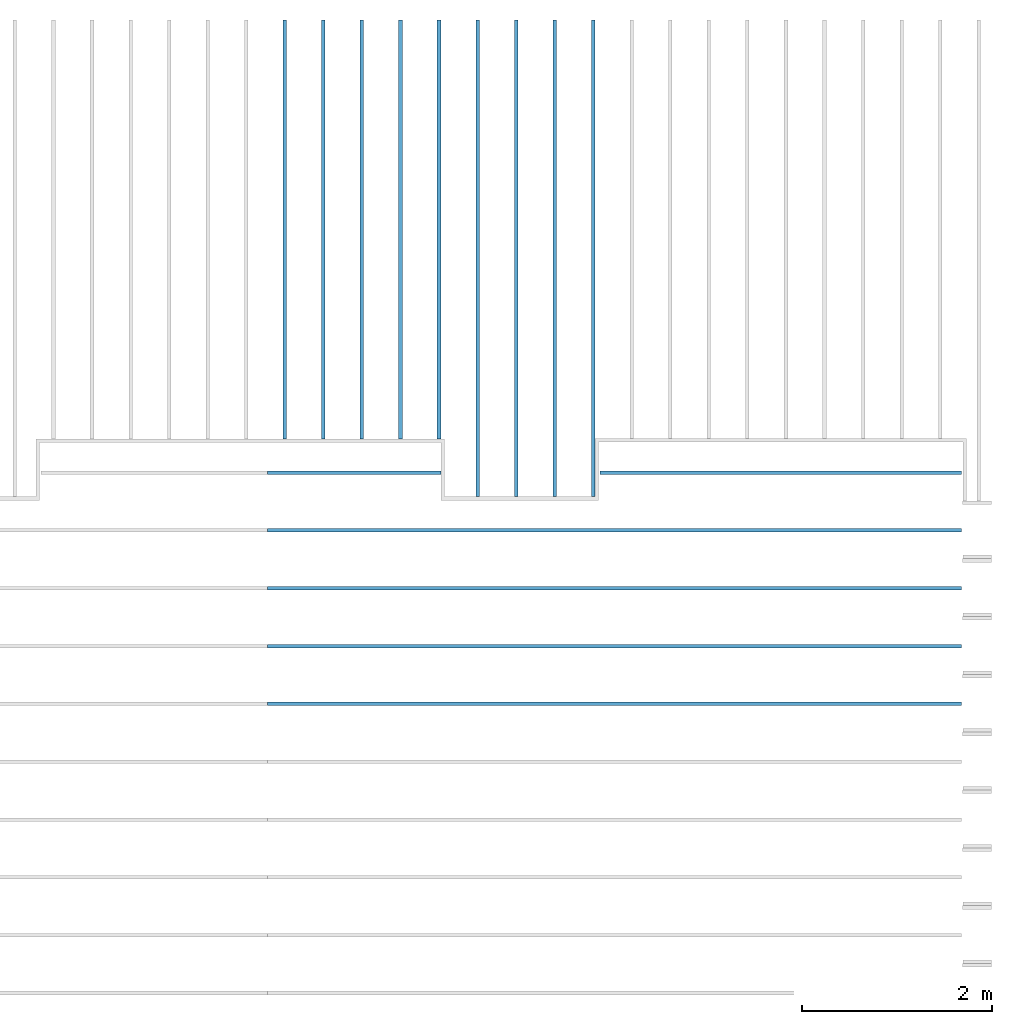
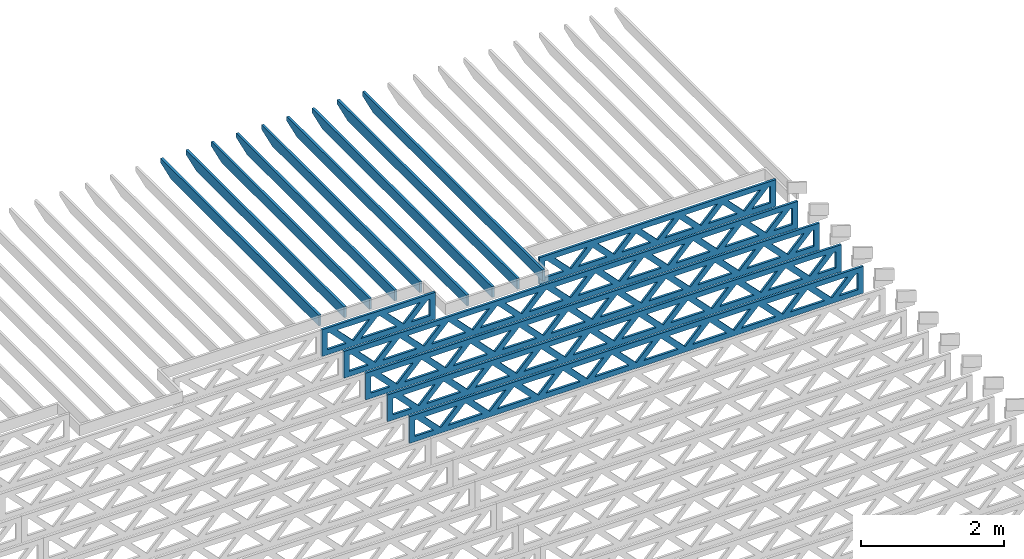
# One storey, part 12 of 17: 15 beams, 2 elements without a shape of their own.
"""IFC4 building model written with IfcOpenShell, lengths in feet."""

from ifc_helpers import new_model, entity, si_unit, converted_unit, derived_unit, direction, frame, frame_2d, origin, origin_2d_with_axis, place, context, subcontext, project, spatial, rectangle, extrude, clip, halfspace, source, transform, mapped, material, material_profile, profile_set, profile_usage, type_object, type_shapes, element, aggregate, save


model = new_model("IFC4")

# Units and contexts
model_context = context("Model", 3, precision=0.0001, world=origin(), true_north=direction((6.12303176911189e-17, 1.0)))
body_context = subcontext(model_context, "Body", "Model", "MODEL_VIEW")
ifc_project = project(units=[converted_unit("LENGTHUNIT", "FOOT", entity("IfcRatioMeasure", 0.3048), si_unit("LENGTHUNIT", "METRE"), dimensions=[1, 0, 0, 0, 0, 0, 0]), converted_unit("AREAUNIT", "SQUARE FOOT", entity("IfcRatioMeasure", 0.09290304), si_unit("AREAUNIT", "SQUARE_METRE"), dimensions=[2, 0, 0, 0, 0, 0, 0]), converted_unit("VOLUMEUNIT", "CUBIC FOOT", entity("IfcRatioMeasure", 0.028316846592), si_unit("VOLUMEUNIT", "CUBIC_METRE"), dimensions=[3, 0, 0, 0, 0, 0, 0]), converted_unit("PLANEANGLEUNIT", "DEGREE", entity("IfcRatioMeasure", 0.0174532925199433), si_unit("PLANEANGLEUNIT", "RADIAN"), dimensions=[0, 0, 0, 0, 0, 0, 0]), si_unit("MASSUNIT", "GRAM", prefix="KILO"), derived_unit("MASSDENSITYUNIT", [(si_unit("MASSUNIT", "GRAM", prefix="KILO"), 1), (si_unit("LENGTHUNIT", "METRE"), -3)]), derived_unit("MOMENTOFINERTIAUNIT", [(si_unit("LENGTHUNIT", "METRE"), 4)]), si_unit("TIMEUNIT", "SECOND"), si_unit("FREQUENCYUNIT", "HERTZ"), si_unit("THERMODYNAMICTEMPERATUREUNIT", "DEGREE_CELSIUS"), derived_unit("THERMALTRANSMITTANCEUNIT", [(si_unit("MASSUNIT", "GRAM", prefix="KILO"), 1), (si_unit("THERMODYNAMICTEMPERATUREUNIT", "KELVIN"), -1), (si_unit("TIMEUNIT", "SECOND"), -3)]), derived_unit("VOLUMETRICFLOWRATEUNIT", [(si_unit("LENGTHUNIT", "METRE"), 3), (si_unit("TIMEUNIT", "SECOND"), -1)]), si_unit("ELECTRICCURRENTUNIT", "AMPERE"), si_unit("ELECTRICVOLTAGEUNIT", "VOLT"), si_unit("POWERUNIT", "WATT"), si_unit("FORCEUNIT", "NEWTON"), si_unit("ILLUMINANCEUNIT", "LUX"), si_unit("LUMINOUSFLUXUNIT", "LUMEN"), si_unit("LUMINOUSINTENSITYUNIT", "CANDELA"), derived_unit("USERDEFINED", [(si_unit("MASSUNIT", "GRAM", prefix="KILO"), -1), (si_unit("LENGTHUNIT", "METRE"), -2), (si_unit("TIMEUNIT", "SECOND"), 3), (si_unit("LUMINOUSFLUXUNIT", "LUMEN"), 1)]), derived_unit("LINEARVELOCITYUNIT", [(si_unit("LENGTHUNIT", "METRE"), 1), (si_unit("TIMEUNIT", "SECOND"), -1)]), si_unit("PRESSUREUNIT", "PASCAL"), derived_unit("USERDEFINED", [(si_unit("LENGTHUNIT", "METRE"), -2), (si_unit("MASSUNIT", "GRAM", prefix="KILO"), 1), (si_unit("TIMEUNIT", "SECOND"), -2)]), derived_unit("LINEARFORCEUNIT", [(si_unit("MASSUNIT", "GRAM", prefix="KILO"), 1), (si_unit("LENGTHUNIT", "METRE"), 1), (si_unit("TIMEUNIT", "SECOND"), -2), (si_unit("LENGTHUNIT", "METRE"), -1)]), derived_unit("PLANARFORCEUNIT", [(si_unit("MASSUNIT", "GRAM", prefix="KILO"), 1), (si_unit("LENGTHUNIT", "METRE"), 1), (si_unit("TIMEUNIT", "SECOND"), -2), (si_unit("LENGTHUNIT", "METRE"), -2)])], contexts=[model_context])

# Site, building, storey
site_placement = place(None, origin())
site = spatial("IfcSite", under=ifc_project, at=site_placement, CompositionType="ELEMENT")
building_placement = place(site_placement, origin())
building = spatial("IfcBuilding", under=site, at=building_placement, CompositionType="ELEMENT")
storey_placement = place(building_placement, frame((0.0, 0.0, 30.4375000000082)))
storey = spatial("IfcBuildingStorey", under=building, at=storey_placement, Name="ROOF", CompositionType="ELEMENT", Elevation=30.4375000000082)

# Assembly, beams
assembly_1_placement = place(storey_placement, origin())
assembly_1 = element("IfcElementAssembly", 1, at=assembly_1_placement, inside=storey, Name="Structural Beam System:Structural Framing System", ObjectType="Structural Beam System:Structural Framing System", AssemblyPlace="NOTDEFINED", PredefinedType="BEAM_GRID")
ifc_material_1 = material(Name="WOOD TRUSS", Category="Materials")
ifc_material_profile_1 = material_profile(ifc_material_1, rectangle(XDim=1.73473973950632, YDim=0.125, at=origin_2d_with_axis()))
ifc_material_profile_2 = material_profile(ifc_material_1, rectangle(XDim=1.73473973950633, YDim=0.125, at=frame_2d((-1.11022302462516e-16, 0.0), x_axis=(1.0, 0.0))))
ifc_material_profile_3 = material_profile(ifc_material_1, rectangle(XDim=1.73473973950632, YDim=0.125, at=origin_2d_with_axis()))
ifc_material_profile_4 = material_profile(ifc_material_1, rectangle(XDim=1.73473973950633, YDim=0.125, at=origin_2d_with_axis()))
ifc_material_profile_5 = material_profile(ifc_material_1, rectangle(XDim=1.73473973950632, YDim=0.125, at=frame_2d((-5.55111512312578e-17, 0.0), x_axis=(1.0, 0.0))))
ifc_material_profile_6 = material_profile(ifc_material_1, rectangle(XDim=1.73473973950633, YDim=0.125, at=frame_2d((-2.77555756156289e-16, 0.0), x_axis=(1.0, 0.0))))
ifc_material_profile_7 = material_profile(ifc_material_1, rectangle(XDim=1.73473973950632, YDim=0.125, at=frame_2d((-4.9960036108132e-16, 0.0), x_axis=(1.0, 0.0))))
ifc_material_profile_8 = material_profile(ifc_material_1, rectangle(XDim=1.73473973950633, YDim=0.125, at=frame_2d((4.44089209850063e-16, 0.0), x_axis=(1.0, 0.0))))
ifc_material_profile_9 = material_profile(ifc_material_1, rectangle(XDim=1.73473973950632, YDim=0.125, at=origin_2d_with_axis()))
ifc_material_profile_10 = material_profile(ifc_material_1, rectangle(XDim=1.73473973950633, YDim=0.125, at=frame_2d((-4.9960036108132e-16, 0.0), x_axis=(1.0, 0.0))))
ifc_material_profile_11 = material_profile(ifc_material_1, rectangle(XDim=0.291666666666664, YDim=0.125, at=frame_2d((-2.77555756156289e-17, 0.0), x_axis=(1.0, 0.0))))
ifc_material_profile_12 = material_profile(ifc_material_1, rectangle(XDim=0.291666666666628, YDim=0.124999999999995, at=frame_2d((-5.55111512312578e-17, 0.0), x_axis=(1.0, 0.0))))
ifc_material_profile_13 = material_profile(ifc_material_1, rectangle(XDim=0.916666666666666, YDim=0.125000000000003, at=frame_2d((-2.77555756156289e-17, 0.0), x_axis=(1.0, 0.0))))
ifc_material_profile_14 = material_profile(ifc_material_1, rectangle(XDim=0.916666666666651, YDim=0.125, at=frame_2d((-2.77555756156289e-17, 0.0), x_axis=(1.0, 0.0))))
ifc_profile_set_1 = profile_set([ifc_material_profile_1, ifc_material_profile_2, ifc_material_profile_3, ifc_material_profile_4, ifc_material_profile_5, ifc_material_profile_6, ifc_material_profile_7, ifc_material_profile_8, ifc_material_profile_9, ifc_material_profile_10, ifc_material_profile_11, ifc_material_profile_12, ifc_material_profile_13, ifc_material_profile_14])
ifc_profile_usage_1 = profile_usage(ifc_profile_set_1, cardinal=8)
beam_type_1 = type_object("IfcBeamType", PredefinedType="BEAM", material=ifc_profile_set_1)
shared_shape_1 = source(origin(), body_context, "Body", "SweptSolid", [
    extrude(rectangle(XDim=1.73473973950632, YDim=0.125, at=origin_2d_with_axis()), frame((2.81172855039779, 0.0, 0.101118361020562), z_axis=(0.720569184836762, 0.0, -0.693383046997606), x_axis=(0.693383046997606, 0.0, 0.720569184836762)), (0.0, 0.0, 1.0), 0.291666666666667),
    extrude(rectangle(XDim=1.73473973950633, YDim=0.125, at=frame_2d((-1.11022302462516e-16, 0.0), x_axis=(1.0, 0.0))), frame((1.56144267672452, 0.0, -0.101118361020407), z_axis=(0.720569184836758, 0.0, 0.69338304699761), x_axis=(0.69338304699761, 0.0, -0.720569184836758)), (0.0, 0.0, 1.0), 0.291666666666666),
    extrude(rectangle(XDim=1.73473973950632, YDim=0.125, at=origin_2d_with_axis()), frame((0.520059930714936, 0.0, 0.101118361020562), z_axis=(0.720569184836762, 0.0, -0.693383046997606), x_axis=(0.693383046997606, 0.0, 0.720569184836762)), (0.0, 0.0, 1.0), 0.291666666666667),
    extrude(rectangle(XDim=1.73473973950633, YDim=0.125, at=origin_2d_with_axis()), frame((-0.730225942958334, 0.0, -0.101118361020407), z_axis=(0.720569184836758, 0.0, 0.69338304699761), x_axis=(0.69338304699761, 0.0, -0.720569184836758)), (0.0, 0.0, 1.0), 0.291666666666666),
    extrude(rectangle(XDim=1.73473973950632, YDim=0.125, at=frame_2d((-5.55111512312578e-17, 0.0), x_axis=(1.0, 0.0))), frame((-1.77160868896792, 0.0, 0.101118361020562), z_axis=(0.720569184836762, 0.0, -0.693383046997606), x_axis=(0.693383046997606, 0.0, 0.720569184836762)), (0.0, 0.0, 1.0), 0.291666666666667),
    extrude(rectangle(XDim=1.73473973950633, YDim=0.125, at=frame_2d((-2.77555756156289e-16, 0.0), x_axis=(1.0, 0.0))), frame((-3.02189456264119, 0.0, -0.101118361020407), z_axis=(0.720569184836758, 0.0, 0.69338304699761), x_axis=(0.69338304699761, 0.0, -0.720569184836758)), (0.0, 0.0, 1.0), 0.291666666666666),
    extrude(rectangle(XDim=1.73473973950632, YDim=0.125, at=frame_2d((-4.9960036108132e-16, 0.0), x_axis=(1.0, 0.0))), frame((5.10339717008065, 0.0, 0.101118361020511), z_axis=(0.720569184836761, 0.0, -0.693383046997607), x_axis=(0.693383046997607, 0.0, 0.720569184836761)), (0.0, 0.0, 1.0), 0.291666666666668),
    extrude(rectangle(XDim=1.73473973950633, YDim=0.125, at=frame_2d((4.44089209850063e-16, 0.0), x_axis=(1.0, 0.0))), frame((3.85311129640737, 0.0, -0.101118361020458), z_axis=(0.720569184836758, 0.0, 0.69338304699761), x_axis=(0.69338304699761, 0.0, -0.720569184836758)), (0.0, 0.0, 1.0), 0.291666666666666),
    extrude(rectangle(XDim=1.73473973950632, YDim=0.125, at=origin_2d_with_axis()), frame((-4.06327730865077, 0.0, 0.101118361020557), z_axis=(0.720569184836762, 0.0, -0.693383046997606), x_axis=(0.693383046997606, 0.0, 0.720569184836762)), (0.0, 0.0, 1.0), 0.291666666666668),
    extrude(rectangle(XDim=1.73473973950633, YDim=0.125, at=frame_2d((-4.9960036108132e-16, 0.0), x_axis=(1.0, 0.0))), frame((-5.31356318232404, 0.0, -0.101118361020412), z_axis=(0.720569184836758, 0.0, 0.69338304699761), x_axis=(0.69338304699761, 0.0, -0.720569184836758)), (0.0, 0.0, 1.0), 0.291666666666667),
    extrude(rectangle(XDim=0.291666666666664, YDim=0.125, at=frame_2d((-2.77555756156289e-17, 0.0), x_axis=(1.0, 0.0))), frame((-6.25000390603229, 0.0, 0.604166666666611), z_axis=(1.0, 0.0, 0.0), x_axis=(0.0, 0.0, -1.0)), (0.0, 0.0, 1.0), 12.5000078120646),
    extrude(rectangle(XDim=0.291666666666628, YDim=0.124999999999995, at=frame_2d((-5.55111512312578e-17, 0.0), x_axis=(1.0, 0.0))), frame((-6.25000390603208, 0.0, -0.604166666666693), z_axis=(1.0, 0.0, 0.0), x_axis=(0.0, 0.0, -1.0)), (0.0, 0.0, 1.0), 12.5000078120644),
    extrude(rectangle(XDim=0.916666666666666, YDim=0.125000000000003, at=frame_2d((-2.77555756156289e-17, 0.0), x_axis=(1.0, 0.0))), frame((5.9583372393656, 0.0, 0.0), z_axis=(1.0, 0.0, 0.0), x_axis=(0.0, 0.0, -1.0)), (0.0, 0.0, 1.0), 0.291666666666687),
    extrude(rectangle(XDim=0.916666666666651, YDim=0.125, at=frame_2d((-2.77555756156289e-17, 0.0), x_axis=(1.0, 0.0))), frame((-6.25000390603229, 0.0, 0.0), z_axis=(1.0, 0.0, 0.0), x_axis=(0.0, 0.0, -1.0)), (0.0, 0.0, 1.0), 0.291666666666687),
])
type_shapes(beam_type_1, [shared_shape_1])
beam_1_placement = place(assembly_1_placement, frame((-146.654823274369, 957.861934882651, 0.749999999991619), z_axis=(0.0, 0.0, 1.0), x_axis=(-1.0, 0.0, 0.0)))
beam_1 = element("IfcBeam", 2, at=beam_1_placement, type_object=beam_type_1, material=ifc_profile_usage_1, PredefinedType="BEAM", context=body_context, shape_type="MappedRepresentation", body=[
    mapped(shared_shape_1, transform((0.0, 0.0, 0.0), scale=1.0)),
])
ifc_profile_usage_2 = profile_usage(ifc_profile_set_1, cardinal=8)
beam_type_2 = type_object("IfcBeamType", PredefinedType="BEAM", material=ifc_profile_set_1)
shared_shape_2 = source(origin(), body_context, "Body", "SweptSolid", [
    extrude(rectangle(XDim=1.73473973950632, YDim=0.125, at=frame_2d((5.55111512312578e-17, 0.0), x_axis=(1.0, 0.0))), frame((1.853392761574, 0.0, 0.101118361020515), z_axis=(0.720569184836762, 0.0, -0.693383046997606), x_axis=(0.693383046997606, 0.0, 0.720569184836762)), (0.0, 0.0, 1.0), 0.291666666666667),
    extrude(rectangle(XDim=1.73473973950633, YDim=0.125, at=frame_2d((-1.11022302462516e-16, 0.0), x_axis=(1.0, 0.0))), frame((0.603106887900734, 0.0, -0.101118361020454), z_axis=(0.720569184836758, 0.0, 0.69338304699761), x_axis=(0.69338304699761, 0.0, -0.720569184836758)), (0.0, 0.0, 1.0), 0.291666666666667),
    extrude(rectangle(XDim=1.73473973950632, YDim=0.125, at=frame_2d((-5.55111512312578e-17, 0.0), x_axis=(1.0, 0.0))), frame((-0.813272900144133, 0.0, 0.101118361020554), z_axis=(0.720569184836762, 0.0, -0.693383046997606), x_axis=(0.693383046997606, 0.0, 0.720569184836762)), (0.0, 0.0, 1.0), 0.291666666666667),
    extrude(rectangle(XDim=1.73473973950633, YDim=0.125, at=frame_2d((-1.66533453693773e-16, 0.0), x_axis=(1.0, 0.0))), frame((-2.0635587738174, 0.0, -0.101118361020415), z_axis=(0.720569184836758, 0.0, 0.69338304699761), x_axis=(0.69338304699761, 0.0, -0.720569184836758)), (0.0, 0.0, 1.0), 0.291666666666666),
    extrude(rectangle(XDim=0.291666666666664, YDim=0.125, at=frame_2d((-2.77555756156289e-17, 0.0), x_axis=(1.0, 0.0))), frame((-2.99999949752565, 0.0, 0.604166666666611), z_axis=(1.0, 0.0, 0.0), x_axis=(0.0, 0.0, -1.0)), (0.0, 0.0, 1.0), 5.9999989950513),
    extrude(rectangle(XDim=0.291666666666628, YDim=0.124999999999995, at=frame_2d((-5.55111512312578e-17, 0.0), x_axis=(1.0, 0.0))), frame((-2.99999949752544, 0.0, -0.604166666666693), z_axis=(1.0, 0.0, 0.0), x_axis=(0.0, 0.0, -1.0)), (0.0, 0.0, 1.0), 5.99999899505109),
    extrude(rectangle(XDim=0.916666666666666, YDim=0.125000000000003, at=frame_2d((-2.77555756156289e-17, 0.0), x_axis=(1.0, 0.0))), frame((2.70833283085896, 0.0, 0.0), z_axis=(1.0, 0.0, 0.0), x_axis=(0.0, 0.0, -1.0)), (0.0, 0.0, 1.0), 0.291666666666687),
    extrude(rectangle(XDim=0.916666666666651, YDim=0.125, at=frame_2d((-2.77555756156289e-17, 0.0), x_axis=(1.0, 0.0))), frame((-2.99999949752565, 0.0, 0.0), z_axis=(1.0, 0.0, 0.0), x_axis=(0.0, 0.0, -1.0)), (0.0, 0.0, 1.0), 0.291666666666687),
])
type_shapes(beam_type_2, [shared_shape_2])
beam_2_placement = place(assembly_1_placement, frame((-161.40482765467, 957.861934882651, 0.749999999991616), z_axis=(0.0, 0.0, 1.0), x_axis=(-1.0, 0.0, 0.0)))
beam_2 = element("IfcBeam", 3, at=beam_2_placement, type_object=beam_type_2, material=ifc_profile_usage_2, PredefinedType="BEAM", context=body_context, shape_type="MappedRepresentation", body=[
    mapped(shared_shape_2, transform((0.0, 0.0, 0.0), scale=1.0)),
])
ifc_profile_usage_3 = profile_usage(ifc_profile_set_1, cardinal=8)
beam_type_3 = type_object("IfcBeamType", PredefinedType="BEAM", material=ifc_profile_set_1)
shared_shape_3 = source(origin(), body_context, "Body", "SweptSolid", [
    extrude(rectangle(XDim=1.73473973950632, YDim=0.125, at=frame_2d((8.88178419700125e-16, 0.0), x_axis=(1.0, 0.0))), frame((8.27006284966195, 0.0, 0.101118361020562), z_axis=(0.720569184836762, 0.0, -0.693383046997606), x_axis=(0.693383046997606, 0.0, 0.720569184836762)), (0.0, 0.0, 1.0), 0.291666666666667),
    extrude(rectangle(XDim=1.73473973950633, YDim=0.125, at=frame_2d((4.9960036108132e-16, 0.0), x_axis=(1.0, 0.0))), frame((7.01977697598868, 0.0, -0.101118361020407), z_axis=(0.720569184836758, 0.0, 0.69338304699761), x_axis=(0.69338304699761, 0.0, -0.720569184836758)), (0.0, 0.0, 1.0), 0.291666666666667),
    extrude(rectangle(XDim=1.73473973950632, YDim=0.125, at=origin_2d_with_axis()), frame((5.68672854334628, 0.0, 0.101118361020562), z_axis=(0.720569184836762, 0.0, -0.693383046997606), x_axis=(0.693383046997606, 0.0, 0.720569184836762)), (0.0, 0.0, 1.0), 0.291666666666667),
    extrude(rectangle(XDim=1.73473973950633, YDim=0.125, at=frame_2d((-4.9960036108132e-16, 0.0), x_axis=(1.0, 0.0))), frame((4.43644266967301, 0.0, -0.101118361020407), z_axis=(0.720569184836758, 0.0, 0.69338304699761), x_axis=(0.69338304699761, 0.0, -0.720569184836758)), (0.0, 0.0, 1.0), 0.291666666666667),
    extrude(rectangle(XDim=1.73473973950632, YDim=0.125, at=frame_2d((3.33066907387547e-16, 0.0), x_axis=(1.0, 0.0))), frame((3.10339423703061, 0.0, 0.101118361020562), z_axis=(0.720569184836762, 0.0, -0.693383046997606), x_axis=(0.693383046997606, 0.0, 0.720569184836762)), (0.0, 0.0, 1.0), 0.291666666666667),
    extrude(rectangle(XDim=1.73473973950633, YDim=0.125, at=frame_2d((-1.11022302462516e-16, 0.0), x_axis=(1.0, 0.0))), frame((1.85310836335734, 0.0, -0.101118361020407), z_axis=(0.720569184836758, 0.0, 0.69338304699761), x_axis=(0.69338304699761, 0.0, -0.720569184836758)), (0.0, 0.0, 1.0), 0.291666666666666),
    extrude(rectangle(XDim=1.73473973950632, YDim=0.125, at=frame_2d((5.55111512312578e-17, 0.0), x_axis=(1.0, 0.0))), frame((0.520059930714937, 0.0, 0.101118361020562), z_axis=(0.720569184836762, 0.0, -0.693383046997606), x_axis=(0.693383046997606, 0.0, 0.720569184836762)), (0.0, 0.0, 1.0), 0.291666666666667),
    extrude(rectangle(XDim=1.73473973950633, YDim=0.125, at=origin_2d_with_axis()), frame((-0.730225942958334, 0.0, -0.101118361020407), z_axis=(0.720569184836758, 0.0, 0.69338304699761), x_axis=(0.69338304699761, 0.0, -0.720569184836758)), (0.0, 0.0, 1.0), 0.291666666666666),
    extrude(rectangle(XDim=1.73473973950632, YDim=0.125, at=frame_2d((-5.55111512312578e-17, 0.0), x_axis=(1.0, 0.0))), frame((-2.06327437560074, 0.0, 0.101118361020562), z_axis=(0.720569184836762, 0.0, -0.693383046997606), x_axis=(0.693383046997606, 0.0, 0.720569184836762)), (0.0, 0.0, 1.0), 0.291666666666667),
    extrude(rectangle(XDim=1.73473973950633, YDim=0.125, at=frame_2d((-2.77555756156289e-16, 0.0), x_axis=(1.0, 0.0))), frame((-3.31356024927401, 0.0, -0.101118361020407), z_axis=(0.720569184836758, 0.0, 0.69338304699761), x_axis=(0.69338304699761, 0.0, -0.720569184836758)), (0.0, 0.0, 1.0), 0.291666666666666),
    extrude(rectangle(XDim=1.73473973950632, YDim=0.125, at=origin_2d_with_axis()), frame((-4.64660868191641, 0.0, 0.101118361020562), z_axis=(0.720569184836762, 0.0, -0.693383046997606), x_axis=(0.693383046997606, 0.0, 0.720569184836762)), (0.0, 0.0, 1.0), 0.291666666666667),
    extrude(rectangle(XDim=1.73473973950633, YDim=0.125, at=frame_2d((-4.9960036108132e-16, 0.0), x_axis=(1.0, 0.0))), frame((-5.89689455558968, 0.0, -0.101118361020407), z_axis=(0.720569184836758, 0.0, 0.69338304699761), x_axis=(0.69338304699761, 0.0, -0.720569184836758)), (0.0, 0.0, 1.0), 0.291666666666667),
    extrude(rectangle(XDim=1.73473973950632, YDim=0.125, at=frame_2d((5.55111512312578e-16, 0.0), x_axis=(1.0, 0.0))), frame((-7.22994298823208, 0.0, 0.101118361020562), z_axis=(0.720569184836762, 0.0, -0.693383046997606), x_axis=(0.693383046997606, 0.0, 0.720569184836762)), (0.0, 0.0, 1.0), 0.291666666666667),
    extrude(rectangle(XDim=1.73473973950633, YDim=0.125, at=origin_2d_with_axis()), frame((-8.48022886190535, 0.0, -0.101118361020407), z_axis=(0.720569184836758, 0.0, 0.69338304699761), x_axis=(0.69338304699761, 0.0, -0.720569184836758)), (0.0, 0.0, 1.0), 0.291666666666666),
    extrude(rectangle(XDim=1.73473973950632, YDim=0.125, at=frame_2d((-8.88178419700125e-16, 0.0), x_axis=(1.0, 0.0))), frame((10.8533971559776, 0.0, 0.101118361020503), z_axis=(0.720569184836762, 0.0, -0.693383046997606), x_axis=(0.693383046997606, 0.0, 0.720569184836762)), (0.0, 0.0, 1.0), 0.291666666666664),
    extrude(rectangle(XDim=1.73473973950633, YDim=0.125, at=origin_2d_with_axis()), frame((9.60311128230435, 0.0, -0.101118361020466), z_axis=(0.720569184836758, 0.0, 0.69338304699761), x_axis=(0.69338304699761, 0.0, -0.720569184836758)), (0.0, 0.0, 1.0), 0.291666666666666),
    extrude(rectangle(XDim=1.73473973950632, YDim=0.125, at=frame_2d((8.88178419700125e-16, 0.0), x_axis=(1.0, 0.0))), frame((-9.81327729454775, 0.0, 0.101118361020564), z_axis=(0.720569184836762, 0.0, -0.693383046997606), x_axis=(0.693383046997606, 0.0, 0.720569184836762)), (0.0, 0.0, 1.0), 0.291666666666667),
    extrude(rectangle(XDim=1.73473973950633, YDim=0.125, at=origin_2d_with_axis()), frame((-11.063563168221, 0.0, -0.101118361020405), z_axis=(0.720569184836758, 0.0, 0.69338304699761), x_axis=(0.69338304699761, 0.0, -0.720569184836758)), (0.0, 0.0, 1.0), 0.291666666666666),
    extrude(rectangle(XDim=0.291666666666664, YDim=0.125, at=frame_2d((-2.77555756156289e-17, 0.0), x_axis=(1.0, 0.0))), frame((-12.0000038919293, 0.0, 0.604166666666611), z_axis=(1.0, 0.0, 0.0), x_axis=(0.0, 0.0, -1.0)), (0.0, 0.0, 1.0), 24.0000077838585),
    extrude(rectangle(XDim=0.291666666666628, YDim=0.124999999999995, at=frame_2d((-5.55111512312578e-17, 0.0), x_axis=(1.0, 0.0))), frame((-12.0000038919291, 0.0, -0.604166666666693), z_axis=(1.0, 0.0, 0.0), x_axis=(0.0, 0.0, -1.0)), (0.0, 0.0, 1.0), 24.0000077838583),
    extrude(rectangle(XDim=0.916666666666666, YDim=0.125000000000003, at=frame_2d((-2.77555756156289e-17, 0.0), x_axis=(1.0, 0.0))), frame((11.7083372252626, 0.0, 0.0), z_axis=(1.0, 0.0, 0.0), x_axis=(0.0, 0.0, -1.0)), (0.0, 0.0, 1.0), 0.291666666666687),
    extrude(rectangle(XDim=0.916666666666651, YDim=0.125, at=frame_2d((-2.77555756156289e-17, 0.0), x_axis=(1.0, 0.0))), frame((-12.0000038919293, 0.0, 0.0), z_axis=(1.0, 0.0, 0.0), x_axis=(0.0, 0.0, -1.0)), (0.0, 0.0, 1.0), 0.291666666666687),
])
type_shapes(beam_type_3, [shared_shape_3])
beam_3_placement = place(assembly_1_placement, frame((-152.404823260266, 955.861934882651, 0.749999999991619), z_axis=(0.0, 0.0, 1.0), x_axis=(-1.0, 0.0, 0.0)))
beam_3 = element("IfcBeam", 4, at=beam_3_placement, type_object=beam_type_3, material=ifc_profile_usage_3, PredefinedType="BEAM", context=body_context, shape_type="MappedRepresentation", body=[
    mapped(shared_shape_3, transform((0.0, 0.0, 0.0), scale=1.0)),
])
ifc_profile_usage_4 = profile_usage(ifc_profile_set_1, cardinal=8)
beam_4_placement = place(assembly_1_placement, frame((-152.404823260266, 953.861934882651, 0.749999999991623), z_axis=(0.0, 0.0, 1.0), x_axis=(-1.0, 0.0, 0.0)))
beam_4 = element("IfcBeam", 5, at=beam_4_placement, type_object=beam_type_3, material=ifc_profile_usage_4, PredefinedType="BEAM", context=body_context, shape_type="MappedRepresentation", body=[
    mapped(shared_shape_3, transform((0.0, 0.0, 0.0), scale=1.0)),
])
ifc_profile_usage_5 = profile_usage(ifc_profile_set_1, cardinal=8)
beam_5_placement = place(assembly_1_placement, frame((-152.404823260266, 951.861934882651, 0.74999999999163), z_axis=(0.0, 0.0, 1.0), x_axis=(-1.0, 0.0, 0.0)))
beam_5 = element("IfcBeam", 6, at=beam_5_placement, type_object=beam_type_3, material=ifc_profile_usage_5, PredefinedType="BEAM", context=body_context, shape_type="MappedRepresentation", body=[
    mapped(shared_shape_3, transform((0.0, 0.0, 0.0), scale=1.0)),
])
ifc_profile_usage_6 = profile_usage(ifc_profile_set_1, cardinal=8)
beam_6_placement = place(assembly_1_placement, frame((-152.404823260266, 949.861934882651, 0.749999999991633), z_axis=(0.0, 0.0, 1.0), x_axis=(-1.0, 0.0, 0.0)))
beam_6 = element("IfcBeam", 7, at=beam_6_placement, type_object=beam_type_3, material=ifc_profile_usage_6, PredefinedType="BEAM", context=body_context, shape_type="MappedRepresentation", body=[
    mapped(shared_shape_3, transform((0.0, 0.0, 0.0), scale=1.0)),
])
aggregate(assembly_1, [beam_1, beam_2, beam_3, beam_4, beam_5, beam_6])

assembly_2_placement = place(storey_placement, origin())
assembly_2 = element("IfcElementAssembly", 8, at=assembly_2_placement, inside=storey, Name="Structural Beam System:Structural Framing System", ObjectType="Structural Beam System:Structural Framing System", AssemblyPlace="NOTDEFINED", PredefinedType="BEAM_GRID")
ifc_material_2 = material(Name="2X ROOF JOISTS - EXT. STAIN-1 - SEE LIFE SAFETY", Category="Materials")
ifc_material_profile_15 = material_profile(ifc_material_2, rectangle(XDim=0.604166666666667, YDim=0.125000000000011, at=frame_2d((0.0, 0.0), x_axis=(0.0, 1.0))))
ifc_profile_set_2 = profile_set([ifc_material_profile_15])
ifc_profile_usage_7 = profile_usage(ifc_profile_set_2, cardinal=8)
beam_type_4 = type_object("IfcBeamType", PredefinedType="BEAM", material=ifc_profile_set_2)
shared_shape_4 = source(origin(), body_context, "Body", "Clipping", [
    clip(extrude(rectangle(XDim=0.604166666666667, YDim=0.125000000000011, at=frame_2d((0.0, 0.0), x_axis=(0.0, 1.0))), frame((-8.24296473987818, 0.0, 0.0), z_axis=(1.0, 0.0, 0.0), x_axis=(0.0, 1.0, 0.0)), (0.0, 0.0, 1.0), 16.4859294797564), halfspace(frame((-7.26989982048795, -0.0625000000000026, -0.30208333333334), z_axis=(-0.34202014332567, 0.0, -0.939692620785908), x_axis=(0.0, 1.0, 0.0)), False)),
])
type_shapes(beam_type_4, [shared_shape_4])
beam_7_placement = place(assembly_2_placement, frame((-153.133993818795, 965.271566289195, 1.07291666665829), z_axis=(0.0, 0.0, 1.0), x_axis=(0.0, -1.0, 0.0)))
beam_7 = element("IfcBeam", 9, at=beam_7_placement, type_object=beam_type_4, material=ifc_profile_usage_7, PredefinedType="BEAM", context=body_context, shape_type="MappedRepresentation", body=[
    mapped(shared_shape_4, transform((0.0, 0.0, 0.0), scale=1.0)),
])
ifc_profile_usage_8 = profile_usage(ifc_profile_set_2, cardinal=8)
beam_8_placement = place(assembly_2_placement, frame((-154.467327152128, 965.271566289195, 1.07291666665829), z_axis=(0.0, 0.0, 1.0), x_axis=(0.0, -1.0, 0.0)))
beam_8 = element("IfcBeam", 10, at=beam_8_placement, type_object=beam_type_4, material=ifc_profile_usage_8, PredefinedType="BEAM", context=body_context, shape_type="MappedRepresentation", body=[
    mapped(shared_shape_4, transform((0.0, 0.0, 0.0), scale=1.0)),
])
ifc_profile_usage_9 = profile_usage(ifc_profile_set_2, cardinal=8)
beam_9_placement = place(assembly_2_placement, frame((-155.800660485462, 965.271566289195, 1.07291666665829), z_axis=(0.0, 0.0, 1.0), x_axis=(0.0, -1.0, 0.0)))
beam_9 = element("IfcBeam", 11, at=beam_9_placement, type_object=beam_type_4, material=ifc_profile_usage_9, PredefinedType="BEAM", context=body_context, shape_type="MappedRepresentation", body=[
    mapped(shared_shape_4, transform((0.0, 0.0, 0.0), scale=1.0)),
])
ifc_profile_usage_10 = profile_usage(ifc_profile_set_2, cardinal=8)
beam_10_placement = place(assembly_2_placement, frame((-157.133993818795, 965.271566289195, 1.07291666665829), z_axis=(0.0, 0.0, 1.0), x_axis=(0.0, -1.0, 0.0)))
beam_10 = element("IfcBeam", 12, at=beam_10_placement, type_object=beam_type_4, material=ifc_profile_usage_10, PredefinedType="BEAM", context=body_context, shape_type="MappedRepresentation", body=[
    mapped(shared_shape_4, transform((0.0, 0.0, 0.0), scale=1.0)),
])
ifc_profile_usage_11 = profile_usage(ifc_profile_set_2, cardinal=8)
beam_type_5 = type_object("IfcBeamType", PredefinedType="BEAM", material=ifc_profile_set_2)
shared_shape_5 = source(origin(), body_context, "Body", "Clipping", [
    clip(extrude(rectangle(XDim=0.604166666666667, YDim=0.125000000000011, at=frame_2d((0.0, 0.0), x_axis=(0.0, 1.0))), frame((-7.2429634471444, 0.0, 0.0), z_axis=(1.0, 0.0, 0.0), x_axis=(0.0, 1.0, 0.0)), (0.0, 0.0, 1.0), 14.4859268942888), halfspace(frame((-6.26989852775418, -0.0625000000000026, -0.30208333333334), z_axis=(-0.34202014332567, 0.0, -0.939692620785908), x_axis=(0.0, 1.0, 0.0)), False)),
])
type_shapes(beam_type_5, [shared_shape_5])
beam_11_placement = place(assembly_2_placement, frame((-158.467327152128, 966.271567581929, 1.07291666665829), z_axis=(0.0, 0.0, 1.0), x_axis=(0.0, -1.0, 0.0)))
beam_11 = element("IfcBeam", 13, at=beam_11_placement, type_object=beam_type_5, material=ifc_profile_usage_11, PredefinedType="BEAM", context=body_context, shape_type="MappedRepresentation", body=[
    mapped(shared_shape_5, transform((0.0, 0.0, 0.0), scale=1.0)),
])
ifc_profile_usage_12 = profile_usage(ifc_profile_set_2, cardinal=8)
beam_type_6 = type_object("IfcBeamType", PredefinedType="BEAM", material=ifc_profile_set_2)
shared_shape_6 = source(origin(), body_context, "Body", "Clipping", [
    clip(extrude(rectangle(XDim=0.604166666666667, YDim=0.125000000000011, at=frame_2d((0.0, 0.0), x_axis=(0.0, 1.0))), frame((-7.24296361464559, 0.0, 0.0), z_axis=(1.0, 0.0, 0.0), x_axis=(0.0, 1.0, 0.0)), (0.0, 0.0, 1.0), 14.4859272292912), halfspace(frame((-6.26989869525536, -0.0625000000000026, -0.30208333333334), z_axis=(-0.34202014332567, 0.0, -0.939692620785908), x_axis=(0.0, 1.0, 0.0)), False)),
])
type_shapes(beam_type_6, [shared_shape_6])
beam_12_placement = place(assembly_2_placement, frame((-159.800660485462, 966.271567414428, 1.07291666665829), z_axis=(0.0, 0.0, 1.0), x_axis=(0.0, -1.0, 0.0)))
beam_12 = element("IfcBeam", 14, at=beam_12_placement, type_object=beam_type_6, material=ifc_profile_usage_12, PredefinedType="BEAM", context=body_context, shape_type="MappedRepresentation", body=[
    mapped(shared_shape_6, transform((0.0, 0.0, 0.0), scale=1.0)),
])
ifc_profile_usage_13 = profile_usage(ifc_profile_set_2, cardinal=8)
beam_type_7 = type_object("IfcBeamType", PredefinedType="BEAM", material=ifc_profile_set_2)
shared_shape_7 = source(origin(), body_context, "Body", "Clipping", [
    clip(extrude(rectangle(XDim=0.604166666666667, YDim=0.125000000000011, at=frame_2d((0.0, 0.0), x_axis=(0.0, 1.0))), frame((-7.24296378214677, 0.0, 0.0), z_axis=(1.0, 0.0, 0.0), x_axis=(0.0, 1.0, 0.0)), (0.0, 0.0, 1.0), 14.4859275642935), halfspace(frame((-6.26989886275655, -0.0625000000000026, -0.30208333333334), z_axis=(-0.34202014332567, 0.0, -0.939692620785908), x_axis=(0.0, 1.0, 0.0)), False)),
])
type_shapes(beam_type_7, [shared_shape_7])
beam_13_placement = place(assembly_2_placement, frame((-161.133993818795, 966.271567246926, 1.07291666665829), z_axis=(0.0, 0.0, 1.0), x_axis=(0.0, -1.0, 0.0)))
beam_13 = element("IfcBeam", 15, at=beam_13_placement, type_object=beam_type_7, material=ifc_profile_usage_13, PredefinedType="BEAM", context=body_context, shape_type="MappedRepresentation", body=[
    mapped(shared_shape_7, transform((0.0, 0.0, 0.0), scale=1.0)),
])
ifc_profile_usage_14 = profile_usage(ifc_profile_set_2, cardinal=8)
beam_type_8 = type_object("IfcBeamType", PredefinedType="BEAM", material=ifc_profile_set_2)
shared_shape_8 = source(origin(), body_context, "Body", "Clipping", [
    clip(extrude(rectangle(XDim=0.604166666666667, YDim=0.125000000000011, at=frame_2d((0.0, 0.0), x_axis=(0.0, 1.0))), frame((-7.24296394964796, 0.0, 0.0), z_axis=(1.0, 0.0, 0.0), x_axis=(0.0, 1.0, 0.0)), (0.0, 0.0, 1.0), 14.4859278992959), halfspace(frame((-6.26989903025773, -0.0625000000000026, -0.30208333333334), z_axis=(-0.34202014332567, 0.0, -0.939692620785908), x_axis=(0.0, 1.0, 0.0)), False)),
])
type_shapes(beam_type_8, [shared_shape_8])
beam_14_placement = place(assembly_2_placement, frame((-162.467327152128, 966.271567079425, 1.07291666665829), z_axis=(0.0, 0.0, 1.0), x_axis=(0.0, -1.0, 0.0)))
beam_14 = element("IfcBeam", 16, at=beam_14_placement, type_object=beam_type_8, material=ifc_profile_usage_14, PredefinedType="BEAM", context=body_context, shape_type="MappedRepresentation", body=[
    mapped(shared_shape_8, transform((0.0, 0.0, 0.0), scale=1.0)),
])
ifc_profile_usage_15 = profile_usage(ifc_profile_set_2, cardinal=8)
beam_type_9 = type_object("IfcBeamType", PredefinedType="BEAM", material=ifc_profile_set_2)
shared_shape_9 = source(origin(), body_context, "Body", "Clipping", [
    clip(extrude(rectangle(XDim=0.604166666666667, YDim=0.125000000000011, at=frame_2d((0.0, 0.0), x_axis=(0.0, 1.0))), frame((-7.24296411714914, 0.0, 0.0), z_axis=(1.0, 0.0, 0.0), x_axis=(0.0, 1.0, 0.0)), (0.0, 0.0, 1.0), 14.4859282342983), halfspace(frame((-6.26989919775892, -0.0625000000000026, -0.30208333333334), z_axis=(-0.34202014332567, 0.0, -0.939692620785908), x_axis=(0.0, 1.0, 0.0)), False)),
])
type_shapes(beam_type_9, [shared_shape_9])
beam_15_placement = place(assembly_2_placement, frame((-163.800660485462, 966.271566911924, 1.07291666665829), z_axis=(0.0, 0.0, 1.0), x_axis=(0.0, -1.0, 0.0)))
beam_15 = element("IfcBeam", 17, at=beam_15_placement, type_object=beam_type_9, material=ifc_profile_usage_15, PredefinedType="BEAM", context=body_context, shape_type="MappedRepresentation", body=[
    mapped(shared_shape_9, transform((0.0, 0.0, 0.0), scale=1.0)),
])
aggregate(assembly_2, [beam_7, beam_8, beam_9, beam_10, beam_11, beam_12, beam_13, beam_14, beam_15])

save(model, "model.ifc")
